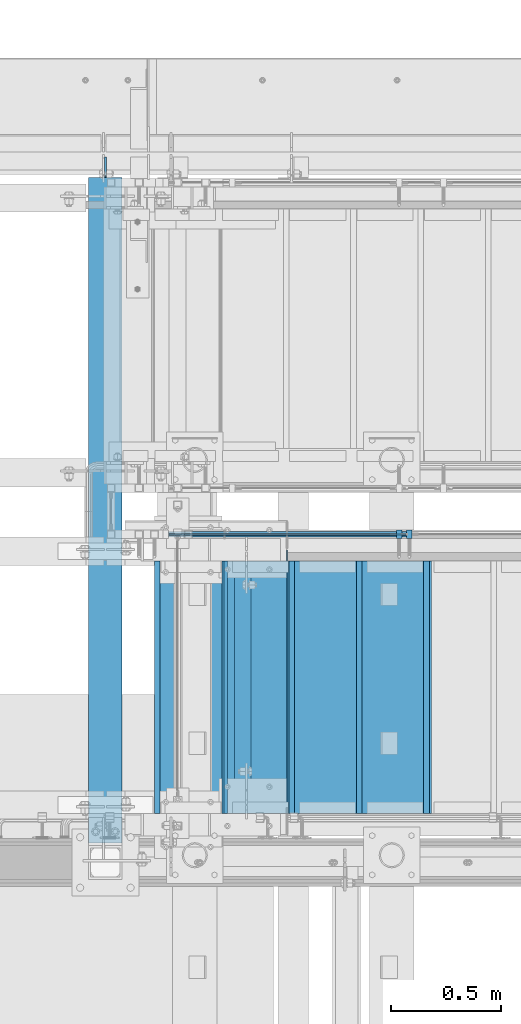
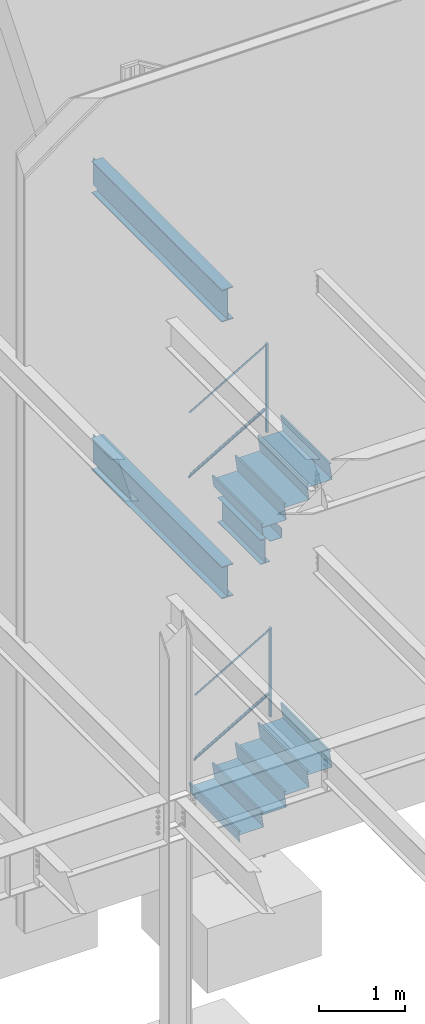
# One storey, part 781 of 1179: 17 beams, 4 members, 7 elements without a shape of their own.
"""IFC2X3 building model written with IfcOpenShell, lengths in millimetres."""

from ifc_helpers import new_model, si_unit, frame, origin_with_axes, place, context, subcontext, project, spatial, faceted_brep, material, type_object, element, aggregate, save


model = new_model("IFC2X3")

# Units and contexts
model_context = context("Model", 3, precision=1e-05, world=origin_with_axes())
body_context = subcontext(model_context, "Body", "Model", "MODEL_VIEW")
ifc_project = project(units=[si_unit("LENGTHUNIT", "METRE", prefix="MILLI"), si_unit("AREAUNIT", "SQUARE_METRE"), si_unit("VOLUMEUNIT", "CUBIC_METRE"), si_unit("MASSUNIT", "GRAM", prefix="KILO"), si_unit("TIMEUNIT", "SECOND"), si_unit("PLANEANGLEUNIT", "RADIAN"), si_unit("SOLIDANGLEUNIT", "STERADIAN"), si_unit("THERMODYNAMICTEMPERATUREUNIT", "DEGREE_CELSIUS"), si_unit("LUMINOUSINTENSITYUNIT", "LUMEN")], contexts=[model_context])

# Site, building, storey
site_placement = place(None, origin_with_axes())
site = spatial("IfcSite", under=ifc_project, at=site_placement, CompositionType="ELEMENT")
building_placement = place(site_placement, origin_with_axes())
building = spatial("IfcBuilding", under=site, at=building_placement, Name="Undefined", CompositionType="ELEMENT")
storey_placement = place(building_placement, origin_with_axes())
storey = spatial("IfcBuildingStorey", under=building, at=storey_placement, Name="Undefined", CompositionType="ELEMENT", Elevation=0.0)

# Assembly, member
assembly_1_placement = place(storey_placement, origin_with_axes())
assembly_1 = element("IfcElementAssembly", 1, at=assembly_1_placement, inside=storey, Name="GUARDRAIL", AssemblyPlace="NOTDEFINED", PredefinedType="RIGID_FRAME")
ifc_material_1 = material(Name="STEEL/A36")
member_type_1 = type_object("IfcMemberType", PredefinedType="NOTDEFINED")
member_1_placement = place(assembly_1_placement, frame((20608.9249611471, 39471.5999992249, 4675.98734774651), z_axis=(0.0, -1.0, 0.0), x_axis=(0.0, 0.0, 1.0)))
member_1 = element("IfcMember", 2, at=member_1_placement, type_object=member_type_1, material=ifc_material_1, Name="POST", context=body_context, shape_type="Brep", body=[
    faceted_brep([(0.0, 12.7000000000007, -19.0500000000029), (0.0, 12.7000000000007, 19.0500000000029), (1243.17712591994, 12.7000000000007, 19.0500000000029), (1243.17712591994, 12.7000000000007, -19.0500000000029), (0.0, -12.7000000000007, 19.0500000000029), (1257.99379259886, -12.7000000000007, 19.0500000000029), (0.0, -12.7000000000007, -19.0500000000029), (1257.99379259886, -12.7000000000007, -19.0500000000029)], [[[0, 1, 2, 3]], [[1, 4, 5, 2]], [[4, 6, 7, 5]], [[6, 0, 3, 7]], [[5, 7, 3, 2]], [[6, 4, 1, 0]]]),
])

assembly_2_placement = place(storey_placement, origin_with_axes())
assembly_2 = element("IfcElementAssembly", 3, at=assembly_2_placement, inside=storey, Name="GUARDRAIL", AssemblyPlace="NOTDEFINED", PredefinedType="RIGID_FRAME")
member_2_placement = place(assembly_2_placement, frame((20655.4916297361, 39471.5999999818, 639.554612166878), z_axis=(0.0, -1.0, 0.0), x_axis=(0.0, 0.0, 1.0)))
member_2 = element("IfcMember", 4, at=member_2_placement, type_object=member_type_1, material=ifc_material_1, Name="POST", context=body_context, shape_type="Brep", body=[
    faceted_brep([(0.0, 12.7000000000007, -19.0500000000029), (0.0, 12.7000000000007, 19.0500000000029), (1242.88603593101, 12.7000000000007, 19.0500000000029), (1242.88603593101, 12.7000000000007, -19.0500000000029), (0.0, -12.7000000000007, 19.0500000000029), (1257.59245954642, -12.7000000000007, 19.0500000000029), (0.0, -12.7000000000007, -19.0500000000029), (1257.59245954642, -12.7000000000007, -19.0500000000029)], [[[0, 1, 2, 3]], [[1, 4, 5, 2]], [[4, 6, 7, 5]], [[6, 0, 3, 7]], [[5, 7, 3, 2]], [[6, 4, 1, 0]]]),
])

# Beam
ifc_material_2 = material(Name="STEEL/BUY-OUT")
beam_type_1 = type_object("IfcBeamType", PredefinedType="NOTDEFINED")
beam_1_placement = place(assembly_1_placement, frame((20092.8747927259, 39468.4251646336, 5594.30006097899), z_axis=(-0.86377890071706, 0.0, -0.503871025835012), x_axis=(-0.503871025835012, 0.0, 0.86377890071706)))
beam_1 = element("IfcBeam", 5, at=beam_1_placement, type_object=beam_type_1, material=ifc_material_2, Name="U-EDGE", context=body_context, shape_type="Brep", body=[
    faceted_brep([(-2.62571120401844e-09, 1.58750000000146, -551.090159790514), (22.2250002407682, 1.58750000000146, -589.784707497234), (22.2250002534201, 4.76249998393178, -589.784707519266), (5.1261577027617e-07, 4.76249998815911, -551.090160687567), (5.1261577027617e-07, 7.93749998815474, -551.090160687567), (25.400000253393, 7.93749998378189, -595.312499999403), (25.4000002406228, -1.58750000000146, -595.312499999232), (-2.62571120401844e-09, -1.58750000000146, -551.090159790514), (25.4000002718667, -1.58750000000146, 595.312499998905), (2.76122591458261e-09, -1.58750000000146, 580.723427522342), (2.76122591458261e-09, 1.58750000000146, 580.723427522342), (22.2250002718201, 1.58750000000146, 593.488867387849), (22.2250002590899, 4.76250001617154, 593.48886738054), (5.1151801017113e-07, 4.76250001247536, 580.723427814559), (5.1151801017113e-07, 7.93750001247827, 580.723427814559), (25.4000002590974, 7.93750001621811, 595.31249999873)], [[[0, 1, 2, 3, 4, 5, 6, 7]], [[7, 6, 8, 9]], [[0, 7, 9, 10]], [[1, 0, 10, 11]], [[2, 1, 11, 12]], [[3, 2, 12, 13]], [[4, 3, 13, 14]], [[5, 4, 14, 15]], [[6, 5, 15, 8]], [[14, 13, 12, 11, 10, 9, 8, 15]]]),
])

beam_2_placement = place(assembly_1_placement, frame((20067.2781716815, 39468.4251646336, 4730.12997777495), z_axis=(-0.86377890071706, 0.0, -0.503871025835012), x_axis=(0.503871110270223, 0.0, -0.863778851463181)))
beam_2 = element("IfcBeam", 6, at=beam_2_placement, type_object=beam_type_1, material=ifc_material_2, Name="U-EDGE", context=body_context, shape_type="Brep", body=[
    faceted_brep([(3.39150574291125e-09, 1.58750000000146, 551.090060740255), (3.39150574291125e-09, -1.58750000000146, 551.090060740255), (22.2249999259266, -1.58750000000146, 589.784086195607), (22.2249999386131, -4.76249998396088, 589.784086217693), (-1.22384335554671e-07, -4.76249998815911, 551.090060521277), (-1.22384335554671e-07, -7.93749998815474, 551.090060521277), (25.3999999386497, -7.93749998381099, 595.312500000691), (25.3999999258431, 1.58750000000146, 595.31250000052), (25.3999999312882, -7.93750001618173, -595.312500000728), (25.3999999440939, 1.58750000000146, -595.312500000899), (-3.57522367266938e-09, 1.58750000000146, -580.72370144297), (-3.57522367266938e-09, -1.58750000000146, -580.72370144297), (22.2249999440628, -1.58750000000146, -593.488900187338), (22.2249999312971, -4.76250001613516, -593.488900180007), (-1.35833943204489e-07, -4.76250001247536, -580.723701367002), (-1.35833943204489e-07, -7.93750001247827, -580.723701367002)], [[[0, 1, 2, 3, 4, 5, 6, 7]], [[7, 6, 8, 9]], [[0, 7, 9, 10]], [[1, 0, 10, 11]], [[2, 1, 11, 12]], [[3, 2, 12, 13]], [[4, 3, 13, 14]], [[5, 4, 14, 15]], [[6, 5, 15, 8]], [[14, 13, 12, 11, 10, 9, 8, 15]]]),
])

beam_3_placement = place(assembly_2_placement, frame((20151.1068581109, 39468.4251653905, 1566.57390567071), z_axis=(-0.86540914081269, 0.0, -0.501065882891503), x_axis=(-0.501065882891504, 0.0, 0.86540914081269)))
beam_3 = element("IfcBeam", 7, at=beam_3_placement, type_object=beam_type_1, material=ifc_material_2, Name="U-EDGE", context=body_context, shape_type="Brep", body=[
    faceted_brep([(5.01850081491284e-07, 7.93750000584987, 565.654393641868), (5.01850081491284e-07, 4.76250000584696, 565.654393641868), (22.2250002528726, 4.76250000758591, 578.467765219681), (22.2250002588062, 1.58750000000146, 578.467765223097), (1.87355908565223e-09, 1.58750000000146, 565.654393353612), (1.87355908565223e-09, -1.58750000000146, 565.654393353612), (25.4000002588291, -1.58750000000146, 580.298246897597), (25.4000002528755, 7.93750000761065, 580.298246894159), (25.4000002430021, -1.58750000000146, -581.025000000453), (25.4000002489647, 7.9374999923748, -581.025000000533), (5.01226168125868e-07, 7.93749999444117, -536.968296245806), (5.01226168125868e-07, 4.76249999444553, -536.968296245806), (22.2250002489855, 4.76249999245192, -575.517911967814), (22.225000243081, 1.58750000000146, -575.51791195757), (-1.78260961547494e-09, 1.58750000000146, -536.968295373328), (-1.78260961547494e-09, -1.58750000000146, -536.968295373328)], [[[0, 1, 2, 3, 4, 5, 6, 7]], [[7, 6, 8, 9]], [[0, 7, 9, 10]], [[1, 0, 10, 11]], [[2, 1, 11, 12]], [[3, 2, 12, 13]], [[4, 3, 13, 14]], [[5, 4, 14, 15]], [[6, 5, 15, 8]], [[14, 13, 12, 11, 10, 9, 8, 15]]]),
])

beam_4_placement = place(assembly_2_placement, frame((20125.6526788242, 39468.4251653905, 701.503466228078), z_axis=(-0.86540914081269, 0.0, -0.501065882891503), x_axis=(0.501065782098943, 0.0, -0.865409199170875)))
beam_4 = element("IfcBeam", 8, at=beam_4_placement, type_object=beam_type_1, material=ifc_material_2, Name="U-EDGE", context=body_context, shape_type="Brep", body=[
    faceted_brep([(-3.45607986673713e-10, 1.58750000000146, 536.241472034682), (-3.45607986673713e-10, -1.58750000000146, 536.241472034682), (22.2250001997436, -1.58750000000146, 574.791082474552), (22.2250002132259, -4.76249998287676, 574.791082497944), (4.30125510320067e-07, -4.76249998738058, 536.241472781338), (4.30125510320067e-07, -7.93749998737621, 536.241472781338), (25.400000213227, -7.93749998271232, 580.298169654056), (25.4000001996137, 1.58750000000146, 580.298169630441), (25.4000002140147, -7.93750001730223, -581.024999999514), (25.4000002276443, 1.58750000000146, -581.0249999997), (3.69254848919809e-10, 1.58750000000146, -566.38114146873), (3.69254848919809e-10, -1.58750000000146, -566.38114146873), (22.2250002275978, -1.58750000000146, -579.194516836025), (22.2250002140099, -4.76250001724839, -579.194516828193), (4.23933670390397e-07, -4.76250001332664, -566.381141712925), (4.23933670390397e-07, -7.93750001332955, -566.381141712925)], [[[0, 1, 2, 3, 4, 5, 6, 7]], [[7, 6, 8, 9]], [[0, 7, 9, 10]], [[1, 0, 10, 11]], [[2, 1, 11, 12]], [[3, 2, 12, 13]], [[4, 3, 13, 14]], [[5, 4, 14, 15]], [[6, 5, 15, 8]], [[14, 13, 12, 11, 10, 9, 8, 15]]]),
])

# Member
member_type_2 = type_object("IfcMemberType", PredefinedType="NOTDEFINED")
member_3_placement = place(assembly_1_placement, frame((19551.6499976883, 39471.5999992249, 4390.05744055561), z_axis=(0.0, -1.0, 0.0), x_axis=(0.863778900717086, 0.0, 0.503871025834967)))
member_3 = element("IfcMember", 9, at=member_3_placement, type_object=member_type_2, material=ifc_material_1, Name="BOTTOM_RAIL", context=body_context, shape_type="Brep", body=[
    faceted_brep([(1213.01228510623, 6.35000000066339, 12.6999999999971), (1205.60395629769, -6.3499999993337, 12.6999999999971), (1205.60395629769, -6.3499999993337, -12.6999999999971), (1213.01228510623, 6.35000000066339, -12.6999999999971), (18.4069803798266, 6.34999999998945, 12.6999999999971), (18.4069803798266, 6.34999999998945, -12.6999999999971), (10.9986698027969, -6.35000000000309, -12.6999999999971), (10.9986698027969, -6.35000000000309, 12.6999999999971)], [[[0, 1, 2, 3]], [[4, 5, 6, 7]], [[5, 4, 0, 3]], [[6, 5, 3, 2]], [[7, 6, 2, 1]], [[4, 7, 1, 0]]]),
])

aggregate(assembly_1, [beam_1, beam_2, member_3, member_1])

member_4_placement = place(assembly_2_placement, frame((19621.5000005731, 39471.5999999818, 371.071282857685), z_axis=(0.0, -1.0, 0.0), x_axis=(0.86540914081267, 0.0, 0.501065882891537)))
member_4 = element("IfcMember", 10, at=member_4_placement, type_object=member_type_2, material=ifc_material_1, Name="BOTTOM_RAIL", context=body_context, shape_type="Brep", body=[
    faceted_brep([(1183.80237647433, 6.34999999946194, 12.6999999999971), (1176.44916466662, -6.35000000052969, 12.6999999999971), (1176.44916466662, -6.35000000052969, -12.6999999999971), (1183.80237647433, 6.34999999946194, -12.6999999999971), (18.3517455546971, 6.34999999998763, 12.6999999999971), (18.3517455546971, 6.34999999998763, -12.6999999999971), (10.9985337469952, -6.35000000000582, -12.6999999999971), (10.9985337469952, -6.35000000000582, 12.6999999999971)], [[[0, 1, 2, 3]], [[4, 5, 6, 7]], [[5, 4, 0, 3]], [[6, 5, 3, 2]], [[7, 6, 2, 1]], [[4, 7, 1, 0]]]),
])

aggregate(assembly_2, [beam_3, member_4, beam_4, member_2])

# Assembly, beams
assembly_3_placement = place(storey_placement, origin_with_axes())
assembly_3 = element("IfcElementAssembly", 11, at=assembly_3_placement, inside=storey, Name="BEAM", AssemblyPlace="NOTDEFINED", PredefinedType="RIGID_FRAME")
ifc_material_3 = material(Name="STEEL/A992")
beam_type_2 = type_object("IfcBeamType", Name="W14X22", PredefinedType="NOTDEFINED")
beam_5_placement = place(assembly_3_placement, frame((19926.3, 38274.6249999907, 3927.475), z_axis=(0.0, 0.0, 1.0), x_axis=(0.0, 1.0, 0.0)))
beam_5 = element("IfcBeam", 12, at=beam_5_placement, type_object=beam_type_2, material=ifc_material_3, Name="BEAM", ObjectType="W14X22", context=body_context, shape_type="Brep", body=[
    faceted_brep([(47.6250000097862, -63.5, -174.625), (47.6250000097862, 63.5, -174.625), (1044.5750000186, 63.5, -174.625), (1044.5750000186, -63.5, -174.625), (47.6250000097862, -63.5, -166.6875), (47.6250000097862, -3.17499999999927, -166.6875), (47.6250000097862, -3.17499999999927, 166.6875), (47.6250000097862, -63.5, 166.6875), (47.6250000097862, -63.5, 174.625), (47.6250000097862, 63.5, 174.625), (47.6250000097862, 63.5, 166.6875), (47.6250000097862, 3.17499999999927, 166.6875), (47.6250000097862, 3.17499999999927, 137.265000000094), (47.6250000097862, 3.17499999999927, -92.8149999999823), (47.6250000097862, 3.17499999999927, -166.6875), (47.6250000097862, 63.5, -166.6875), (1044.5750000186, -63.5, -166.6875), (1044.5750000186, -3.17499999999927, -166.6875), (1044.5750000186, -3.17499999999927, 166.6875), (1044.5750000186, -63.5, 166.6875), (1044.5750000186, -63.5, 174.625), (1044.5750000186, 63.5, 174.625), (1044.5750000186, 63.5, 166.6875), (1044.5750000186, 3.17499999999927, 166.6875), (1044.5750000186, 3.17499999999927, 137.265000000094), (1044.5750000186, 3.17499999999927, -92.8149999999823), (1044.5750000186, 3.17499999999927, -166.6875), (1044.5750000186, 63.5, -166.6875)], [[[0, 1, 2, 3]], [[0, 4, 5, 6, 7, 8, 9, 10, 11, 12, 13, 14, 15, 1]], [[5, 4, 16, 17]], [[6, 5, 17, 18]], [[7, 6, 18, 19]], [[8, 7, 19, 20]], [[9, 8, 20, 21]], [[10, 9, 21, 22]], [[11, 10, 22, 23]], [[14, 13, 12, 11, 23, 24, 25, 26]], [[15, 14, 26, 27]], [[1, 15, 27, 2]], [[26, 25, 24, 23, 22, 21, 20, 19, 18, 17, 16, 3, 2, 27]], [[4, 0, 3, 16]]]),
])
beam_type_3 = type_object("IfcBeamType", PredefinedType="NOTDEFINED")
beam_6_placement = place(assembly_3_placement, frame((19939.0, 38820.7250000005, 4105.275), z_axis=(0.0, -1.0, 0.0), x_axis=(1.0, 0.0, 0.0)))
beam_6 = element("IfcBeam", 13, at=beam_6_placement, type_object=beam_type_3, material=ifc_material_1, Name="BENT_PLATE", context=body_context, shape_type="Brep", body=[
    faceted_brep([(0.0, -3.17500000000018, -581.025000000001), (0.0, -3.17500000000018, 581.025000000001), (0.0, 3.17500000000018, 581.025000000001), (0.0, 3.17500000000018, -581.025000000001), (158.75, 3.17500000000018, 581.025000000001), (158.75, 3.17500000000018, -581.025000000001), (165.099999999999, -3.17500000000018, -581.025000000001), (165.099999999999, -3.17500000000018, 581.025000000001), (158.75, 130.175, 581.025000000001), (158.75, 130.175, -581.025000000001), (165.099999999999, 130.175, 581.025000000001), (165.099999999999, 130.175, -581.025000000001)], [[[0, 1, 2, 3]], [[3, 2, 4, 5]], [[1, 0, 6, 7]], [[5, 4, 8, 9]], [[4, 2, 1, 7, 10, 8]], [[7, 6, 11, 10]], [[6, 0, 3, 5, 9, 11]], [[10, 11, 9, 8]]]),
])
aggregate(assembly_3, [beam_6, beam_5])

assembly_4_placement = place(storey_placement, origin_with_axes())
assembly_4 = element("IfcElementAssembly", 14, at=assembly_4_placement, inside=storey, Name="STAIR", AssemblyPlace="NOTDEFINED", PredefinedType="RIGID_FRAME")
beam_type_4 = type_object("IfcBeamType", PredefinedType="NOTDEFINED")
beam_7_placement = place(assembly_4_placement, frame((20745.4500001582, 38779.4500001282, 4945.36000000019), z_axis=(0.0, -1.0, 0.0), x_axis=(-1.0, 0.0, 0.0)))
beam_7 = element("IfcBeam", 15, at=beam_7_placement, type_object=beam_type_4, material=ifc_material_1, Name="TREAD", context=body_context, shape_type="Brep", body=[
    faceted_brep([(0.0, -1.28999999999996, -571.5), (0.0, -1.28999999999996, 571.5), (0.0, 1.28999999999996, 571.5), (0.0, 1.28999999999996, -571.5), (22.4252350064853, 1.28999999999996, 571.5), (22.4252350064853, 1.28999999999996, -571.5), (25.4000000000015, -1.28999999999996, -571.5), (25.4000000000015, -1.28999999999996, 571.5), (-10.2319078506589, 229.89, 571.5), (-10.2319078506589, 229.89, -571.5), (-7.25714285714275, 227.31, -571.5), (-7.25714285714275, 227.31, 571.5), (319.968697988821, 229.89, 571.5), (319.968697988821, 229.89, -571.5), (317.731075852447, 227.31, -571.5), (317.731075852447, 227.31, 571.5), (325.673299218732, 189.957791390602, 571.5), (325.673299218732, 189.957791390602, -571.5), (323.119229525088, 189.592924291511, 571.5), (323.119229525088, 189.592924291511, -571.5)], [[[0, 1, 2, 3]], [[3, 2, 4, 5]], [[1, 0, 6, 7]], [[5, 4, 8, 9]], [[7, 6, 10, 11]], [[9, 8, 12, 13]], [[11, 10, 14, 15]], [[13, 12, 16, 17]], [[12, 8, 4, 2, 1, 7, 11, 15, 18, 16]], [[15, 14, 19, 18]], [[14, 10, 6, 0, 3, 5, 9, 13, 17, 19]], [[18, 19, 17, 16]]]),
])
beam_8_placement = place(assembly_4_placement, frame((20440.6500001811, 38779.4500001282, 4767.56000000019), z_axis=(0.0, -1.0, 0.0), x_axis=(-1.0, 0.0, 0.0)))
beam_8 = element("IfcBeam", 16, at=beam_8_placement, type_object=beam_type_4, material=ifc_material_1, Name="TREAD", context=body_context, shape_type="Brep", body=[
    faceted_brep([(0.0, -1.28999999999996, -571.5), (0.0, -1.28999999999996, 571.5), (0.0, 1.28999999999996, 571.5), (0.0, 1.28999999999996, -571.5), (22.4252350064853, 1.28999999999996, 571.5), (22.4252350064853, 1.28999999999996, -571.5), (25.4000000000015, -1.28999999999996, -571.5), (25.4000000000015, -1.28999999999996, 571.5), (-10.2319078506589, 229.89, 571.5), (-10.2319078506589, 229.89, -571.5), (-7.25714285714275, 227.31, -571.5), (-7.25714285714275, 227.31, 571.5), (319.968697988821, 229.89, 571.5), (319.968697988821, 229.89, -571.5), (317.731075852447, 227.31, -571.5), (317.731075852447, 227.31, 571.5), (325.673299218732, 189.957791390602, 571.5), (325.673299218732, 189.957791390602, -571.5), (323.119229525088, 189.592924291511, 571.5), (323.119229525088, 189.592924291511, -571.5)], [[[0, 1, 2, 3]], [[3, 2, 4, 5]], [[1, 0, 6, 7]], [[5, 4, 8, 9]], [[7, 6, 10, 11]], [[9, 8, 12, 13]], [[11, 10, 14, 15]], [[13, 12, 16, 17]], [[12, 8, 4, 2, 1, 7, 11, 15, 18, 16]], [[15, 14, 19, 18]], [[14, 10, 6, 0, 3, 5, 9, 13, 17, 19]], [[18, 19, 17, 16]]]),
])
beam_9_placement = place(assembly_4_placement, frame((20135.8500002041, 38779.4500001282, 4589.76000000019), z_axis=(0.0, -1.0, 0.0), x_axis=(-1.0, 0.0, 0.0)))
beam_9 = element("IfcBeam", 17, at=beam_9_placement, type_object=beam_type_4, material=ifc_material_1, Name="TREAD", context=body_context, shape_type="Brep", body=[
    faceted_brep([(0.0, -1.28999999999996, -571.5), (0.0, -1.28999999999996, 571.5), (0.0, 1.28999999999996, 571.5), (0.0, 1.28999999999996, -571.5), (22.4252350064853, 1.28999999999996, 571.5), (22.4252350064853, 1.28999999999996, -571.5), (25.4000000000015, -1.28999999999996, -571.5), (25.4000000000015, -1.28999999999996, 571.5), (-10.2319078506589, 229.89, 571.5), (-10.2319078506589, 229.89, -571.5), (-7.25714285714275, 227.31, -571.5), (-7.25714285714275, 227.31, 571.5), (319.968697988821, 229.89, 571.5), (319.968697988821, 229.89, -571.5), (317.731075852447, 227.31, -571.5), (317.731075852447, 227.31, 571.5), (325.673299218732, 189.957791390602, 571.5), (325.673299218732, 189.957791390602, -571.5), (323.119229525088, 189.592924291511, 571.5), (323.119229525088, 189.592924291511, -571.5)], [[[0, 1, 2, 3]], [[3, 2, 4, 5]], [[1, 0, 6, 7]], [[5, 4, 8, 9]], [[7, 6, 10, 11]], [[9, 8, 12, 13]], [[11, 10, 14, 15]], [[13, 12, 16, 17]], [[12, 8, 4, 2, 1, 7, 11, 15, 18, 16]], [[15, 14, 19, 18]], [[14, 10, 6, 0, 3, 5, 9, 13, 17, 19]], [[18, 19, 17, 16]]]),
])

assembly_5_placement = place(storey_placement, origin_with_axes())
assembly_5 = element("IfcElementAssembly", 18, at=assembly_5_placement, inside=storey, Name="STAIR", AssemblyPlace="NOTDEFINED", PredefinedType="RIGID_FRAME")
beam_10_placement = place(assembly_5_placement, frame((20745.4500002204, 38779.4500000327, 881.095416400779), z_axis=(0.0, -1.0, 0.0), x_axis=(-1.0, 0.0, 0.0)))
beam_10 = element("IfcBeam", 19, at=beam_10_placement, type_object=beam_type_4, material=ifc_material_1, Name="TREAD", context=body_context, shape_type="Brep", body=[
    faceted_brep([(0.0, -1.28999999999996, -571.5), (0.0, -1.28999999999996, 571.5), (0.0, 1.28999999999996, 571.5), (0.0, 1.28999999999996, -571.5), (22.4220799334253, 1.28999999999996, 571.5), (22.4220799334253, 1.28999999999996, -571.5), (25.4000000000015, -1.28999999999996, -571.5), (25.4000000000015, -1.28999999999996, 571.5), (-10.2894642965184, 228.56708328371, 571.5), (-10.2894642965184, 228.56708328371, -571.5), (-7.31154422994223, 225.98708328371, -571.5), (-7.31154422994223, 225.98708328371, 571.5), (319.911141878769, 228.56708328371, 571.5), (319.911141878769, 228.56708328371, -571.5), (317.675890478069, 225.98708328371, -571.5), (317.675890478069, 225.98708328371, 571.5), (325.657303794516, 188.643229151176, 571.5), (325.657303794516, 188.643229151176, -571.5), (323.103618368372, 188.27568222317, 571.5), (323.103618368372, 188.27568222317, -571.5)], [[[0, 1, 2, 3]], [[3, 2, 4, 5]], [[1, 0, 6, 7]], [[5, 4, 8, 9]], [[7, 6, 10, 11]], [[9, 8, 12, 13]], [[11, 10, 14, 15]], [[13, 12, 16, 17]], [[12, 8, 4, 2, 1, 7, 11, 15, 18, 16]], [[15, 14, 19, 18]], [[14, 10, 6, 0, 3, 5, 9, 13, 17, 19]], [[18, 19, 17, 16]]]),
])
beam_11_placement = place(assembly_5_placement, frame((20440.6500001937, 38779.450000034, 704.61833312158), z_axis=(0.0, -1.0, 0.0), x_axis=(-1.0, 0.0, 0.0)))
beam_11 = element("IfcBeam", 20, at=beam_11_placement, type_object=beam_type_4, material=ifc_material_1, Name="TREAD", context=body_context, shape_type="Brep", body=[
    faceted_brep([(0.0, -1.28999999999996, -571.5), (0.0, -1.28999999999996, 571.5), (0.0, 1.28999999999996, 571.5), (0.0, 1.28999999999996, -571.5), (22.4220799334253, 1.28999999999996, 571.5), (22.4220799334253, 1.28999999999996, -571.5), (25.4000000000015, -1.28999999999996, -571.5), (25.4000000000015, -1.28999999999996, 571.5), (-10.2894642965184, 228.56708328371, 571.5), (-10.2894642965184, 228.56708328371, -571.5), (-7.31154422994223, 225.98708328371, -571.5), (-7.31154422994223, 225.98708328371, 571.5), (319.911141878769, 228.56708328371, 571.5), (319.911141878769, 228.56708328371, -571.5), (317.675890478069, 225.98708328371, -571.5), (317.675890478069, 225.98708328371, 571.5), (325.657303794516, 188.643229151176, 571.5), (325.657303794516, 188.643229151176, -571.5), (323.103618368372, 188.27568222317, 571.5), (323.103618368372, 188.27568222317, -571.5)], [[[0, 1, 2, 3]], [[3, 2, 4, 5]], [[1, 0, 6, 7]], [[5, 4, 8, 9]], [[7, 6, 10, 11]], [[9, 8, 12, 13]], [[11, 10, 14, 15]], [[13, 12, 16, 17]], [[12, 8, 4, 2, 1, 7, 11, 15, 18, 16]], [[15, 14, 19, 18]], [[14, 10, 6, 0, 3, 5, 9, 13, 17, 19]], [[18, 19, 17, 16]]]),
])
beam_12_placement = place(assembly_5_placement, frame((20135.8500001669, 38779.4500000353, 528.141249842382), z_axis=(0.0, -1.0, 0.0), x_axis=(-1.0, 0.0, 0.0)))
beam_12 = element("IfcBeam", 21, at=beam_12_placement, type_object=beam_type_4, material=ifc_material_1, Name="TREAD", context=body_context, shape_type="Brep", body=[
    faceted_brep([(0.0, -1.28999999999996, -571.5), (0.0, -1.28999999999996, 571.5), (0.0, 1.28999999999996, 571.5), (0.0, 1.28999999999996, -571.5), (22.4220799334253, 1.28999999999996, 571.5), (22.4220799334253, 1.28999999999996, -571.5), (25.4000000000015, -1.28999999999996, -571.5), (25.4000000000015, -1.28999999999996, 571.5), (-10.2894642965184, 228.56708328371, 571.5), (-10.2894642965184, 228.56708328371, -571.5), (-7.31154422994223, 225.98708328371, -571.5), (-7.31154422994223, 225.98708328371, 571.5), (319.911141878769, 228.56708328371, 571.5), (319.911141878769, 228.56708328371, -571.5), (317.675890478069, 225.98708328371, -571.5), (317.675890478069, 225.98708328371, 571.5), (325.657303794516, 188.643229151176, 571.5), (325.657303794516, 188.643229151176, -571.5), (323.103618368372, 188.27568222317, 571.5), (323.103618368372, 188.27568222317, -571.5)], [[[0, 1, 2, 3]], [[3, 2, 4, 5]], [[1, 0, 6, 7]], [[5, 4, 8, 9]], [[7, 6, 10, 11]], [[9, 8, 12, 13]], [[11, 10, 14, 15]], [[13, 12, 16, 17]], [[12, 8, 4, 2, 1, 7, 11, 15, 18, 16]], [[15, 14, 19, 18]], [[14, 10, 6, 0, 3, 5, 9, 13, 17, 19]], [[18, 19, 17, 16]]]),
])
beam_13_placement = place(assembly_5_placement, frame((19831.0500001401, 38779.4500000366, 351.664166563183), z_axis=(0.0, -1.0, 0.0), x_axis=(-1.0, 0.0, 0.0)))
beam_13 = element("IfcBeam", 22, at=beam_13_placement, type_object=beam_type_4, material=ifc_material_1, Name="TREAD", context=body_context, shape_type="Brep", body=[
    faceted_brep([(0.0, -1.28999999999996, -571.5), (0.0, -1.28999999999996, 571.5), (0.0, 1.28999999999996, 571.5), (0.0, 1.28999999999996, -571.5), (22.4220799334253, 1.28999999999996, 571.5), (22.4220799334253, 1.28999999999996, -571.5), (25.4000000000015, -1.28999999999996, -571.5), (25.4000000000015, -1.28999999999996, 571.5), (-10.2894642965184, 228.56708328371, 571.5), (-10.2894642965184, 228.56708328371, -571.5), (-7.31154422994223, 225.98708328371, -571.5), (-7.31154422994223, 225.98708328371, 571.5), (319.911141878769, 228.56708328371, 571.5), (319.911141878769, 228.56708328371, -571.5), (317.675890478069, 225.98708328371, -571.5), (317.675890478069, 225.98708328371, 571.5), (325.657303794516, 188.643229151176, 571.5), (325.657303794516, 188.643229151176, -571.5), (323.103618368372, 188.27568222317, 571.5), (323.103618368372, 188.27568222317, -571.5)], [[[0, 1, 2, 3]], [[3, 2, 4, 5]], [[1, 0, 6, 7]], [[5, 4, 8, 9]], [[7, 6, 10, 11]], [[9, 8, 12, 13]], [[11, 10, 14, 15]], [[13, 12, 16, 17]], [[12, 8, 4, 2, 1, 7, 11, 15, 18, 16]], [[15, 14, 19, 18]], [[14, 10, 6, 0, 3, 5, 9, 13, 17, 19]], [[18, 19, 17, 16]]]),
])

# Beam
beam_type_5 = type_object("IfcBeamType", PredefinedType="NOTDEFINED")
beam_14_placement = place(assembly_4_placement, frame((19831.050000227, 38779.4500001282, 4411.9600000001), z_axis=(0.0, -1.0, 0.0), x_axis=(-1.0, 0.0, 0.0)))
beam_14 = element("IfcBeam", 23, at=beam_14_placement, type_object=beam_type_5, material=ifc_material_1, Name="TREAD", context=body_context, shape_type="Brep", body=[
    faceted_brep([(0.0, -1.28999999999996, -571.5), (0.0, -1.28999999999996, 571.5), (0.0, 1.28999999999996, 571.5), (0.0, 1.28999999999996, -571.5), (22.4252350064853, 1.28999999999996, 571.5), (22.4252350064853, 1.28999999999996, -571.5), (25.4000000000015, -1.28999999999996, -571.5), (25.4000000000015, -1.28999999999996, 571.5), (-0.73978397951214, 163.445132900907, 571.5), (-0.73978397951214, 163.445132900907, -571.5), (1.81428571413198, 163.810000000002, 571.5), (1.81428571413198, 163.810000000002, -571.5)], [[[0, 1, 2, 3]], [[3, 2, 4, 5]], [[1, 0, 6, 7]], [[5, 4, 8, 9]], [[4, 2, 1, 7, 10, 8]], [[7, 6, 11, 10]], [[6, 0, 3, 5, 9, 11]], [[10, 11, 9, 8]]]),
])

aggregate(assembly_4, [beam_7, beam_8, beam_9, beam_14])

beam_type_6 = type_object("IfcBeamType", PredefinedType="NOTDEFINED")
beam_15_placement = place(assembly_5_placement, frame((19526.2500001134, 38779.4500000379, 175.187083283932), z_axis=(0.0, -1.0, 0.0), x_axis=(-1.0, 0.0, 0.0)))
beam_15 = element("IfcBeam", 24, at=beam_15_placement, type_object=beam_type_6, material=ifc_material_1, Name="TREAD", context=body_context, shape_type="Brep", body=[
    faceted_brep([(0.0, -1.28999999999996, -571.5), (0.0, -1.28999999999996, 571.5), (0.0, 1.28999999999996, 571.5), (0.0, 1.28999999999996, -571.5), (22.4220799334253, 1.28999999999996, 571.5), (22.4220799334253, 1.28999999999996, -571.5), (25.4000000000015, -1.28999999999996, -571.5), (25.4000000000015, -1.28999999999996, 571.5), (-0.716273735204595, 162.053353076738, 571.5), (-0.716273735204595, 162.053353076738, -571.5), (1.83741169093992, 162.420900004753, 571.5), (1.83741169093992, 162.420900004753, -571.5)], [[[0, 1, 2, 3]], [[3, 2, 4, 5]], [[1, 0, 6, 7]], [[5, 4, 8, 9]], [[4, 2, 1, 7, 10, 8]], [[7, 6, 11, 10]], [[6, 0, 3, 5, 9, 11]], [[10, 11, 9, 8]]]),
])

aggregate(assembly_5, [beam_10, beam_11, beam_12, beam_13, beam_15])

# Assembly, beam
assembly_6_placement = place(storey_placement, origin_with_axes())
assembly_6 = element("IfcElementAssembly", 25, at=assembly_6_placement, inside=storey, Name="BEAM", AssemblyPlace="NOTDEFINED", PredefinedType="RIGID_FRAME")
beam_type_7 = type_object("IfcBeamType", Name="W18X40", PredefinedType="NOTDEFINED")
beam_16_placement = place(assembly_6_placement, frame((19278.6, 37985.7, 7786.6875), z_axis=(0.0, 0.0, 1.0), x_axis=(0.0, 1.0, 0.0)))
beam_16 = element("IfcBeam", 26, at=beam_16_placement, type_object=beam_type_7, material=ifc_material_3, Name="BEAM", ObjectType="W18X40", context=body_context, shape_type="Brep", body=[
    faceted_brep([(3102.76875, -3.96875, -214.3125), (3102.76875, -76.2000000000007, -214.3125), (3102.76875, -76.2000000000007, -227.0125), (3102.76875, 76.2000000000007, -227.0125), (3102.76875, 76.2000000000007, -214.3125), (3102.76875, 3.96875, -214.3125), (3102.76875, 3.96875, -201.612499809265), (3102.76875, -3.96875, -201.612499809265), (3103.73547992259, 3.96875, -196.752420291219), (3103.73547992259, -3.96875, -196.752420291219), (3106.48849382307, 3.96875, -192.632243823065), (3106.48849382307, -3.96875, -192.632243823065), (3110.60867029122, 3.96875, -189.879229922587), (3110.60867029122, -3.96875, -189.879229922587), (3115.46874980927, 3.96875, -188.912499999999), (3115.46874980927, -3.96875, -188.912499999999), (3194.84375, -3.96875, -188.912499999999), (3194.84375, 3.96875, -188.912499999999), (88.9000000000015, 3.96875, 214.3125), (88.9000000000015, 76.2000000000007, 214.3125), (3102.76875, 76.2000000000007, 214.3125), (3102.76875, 3.96875, 214.3125), (88.9000000000015, -76.2000000000007, -227.0125), (88.9000000000015, -76.2000000000007, -214.3125), (88.9000000000015, -3.96875, -214.3125), (88.9000000000015, -3.96875, 214.3125), (88.9000000000015, -76.2000000000007, 214.3125), (88.9000000000015, -76.2000000000007, 227.0125), (88.9000000000015, 76.2000000000007, 227.0125), (88.9000000000015, 3.96875, -214.3125), (88.9000000000015, 76.2000000000007, -214.3125), (88.9000000000015, 76.2000000000007, -227.0125), (3102.76875, -3.96875, 214.3125), (3102.76875, -76.2000000000007, 214.3125), (3102.76875, -76.2000000000007, 227.0125), (3102.76875, 76.2000000000007, 227.0125), (3102.76875, -3.96875, 201.612499809266), (3102.76875, 3.96875, 201.612499809266), (3103.73547992259, -3.96875, 196.75242029122), (3103.73547992259, 3.96875, 196.75242029122), (3106.48849382307, -3.96875, 192.632243823066), (3106.48849382307, 3.96875, 192.632243823066), (3110.60867029122, -3.96875, 189.879229922588), (3110.60867029122, 3.96875, 189.879229922588), (3115.46874980927, -3.96875, 188.9125), (3115.46874980927, 3.96875, 188.9125), (3194.84375, -3.96875, 188.9125), (3194.84375, 3.96875, 188.9125)], [[[0, 1, 2, 3, 4, 5, 6, 7]], [[7, 6, 8, 9]], [[9, 8, 10, 11]], [[11, 10, 12, 13]], [[13, 12, 14, 15]], [[16, 15, 14, 17]], [[18, 19, 20, 21]], [[22, 23, 24, 25, 26, 27, 28, 19, 18, 29, 30, 31]], [[26, 25, 32, 33]], [[27, 26, 33, 34]], [[28, 27, 34, 35]], [[19, 28, 35, 20]], [[34, 33, 32, 36, 37, 21, 20, 35]], [[38, 39, 37, 36]], [[40, 41, 39, 38]], [[42, 43, 41, 40]], [[44, 45, 43, 42]], [[46, 47, 45, 44]], [[47, 46, 16, 17]], [[12, 10, 8, 6, 5, 29, 18, 21, 37, 39, 41, 43, 45, 47, 17, 14]], [[30, 29, 5, 4]], [[31, 30, 4, 3]], [[22, 31, 3, 2]], [[23, 22, 2, 1]], [[24, 23, 1, 0]], [[46, 44, 42, 40, 38, 36, 32, 25, 24, 0, 7, 9, 11, 13, 15, 16]]]),
])
aggregate(assembly_6, [beam_16])

assembly_7_placement = place(storey_placement, origin_with_axes())
assembly_7 = element("IfcElementAssembly", 27, at=assembly_7_placement, inside=storey, Name="BEAM", AssemblyPlace="NOTDEFINED", PredefinedType="RIGID_FRAME")
beam_17_placement = place(assembly_7_placement, frame((19278.6, 37985.7, 3875.0875), z_axis=(0.0, 0.0, 1.0), x_axis=(0.0, 1.0, 0.0)))
beam_17 = element("IfcBeam", 28, at=beam_17_placement, type_object=beam_type_7, material=ifc_material_3, Name="BEAM", ObjectType="W18X40", context=body_context, shape_type="Brep", body=[
    faceted_brep([(3102.76875, -3.96875, -214.3125), (3102.76875, -76.2000000000007, -214.3125), (3102.76875, -76.2000000000007, -227.0125), (3102.76875, 76.2000000000007, -227.0125), (3102.76875, 76.2000000000007, -214.3125), (3102.76875, 3.96875, -214.3125), (3102.76875, 3.96875, -207.962499809265), (3102.76875, -3.96875, -207.962499809265), (3103.73547992259, 3.96875, -203.102420291219), (3103.73547992259, -3.96875, -203.102420291219), (3106.48849382307, 3.96875, -198.982243823066), (3106.48849382307, -3.96875, -198.982243823066), (3110.60867029122, 3.96875, -196.229229922588), (3110.60867029122, -3.96875, -196.229229922588), (3115.46874980927, 3.96875, -195.2625), (3115.46874980927, -3.96875, -195.2625), (3194.84375, -3.96875, -195.2625), (3194.84375, 3.96875, -195.2625), (88.9000000000015, 3.96875, 214.3125), (88.9000000000015, 76.2000000000007, 214.3125), (3102.76875, 76.2000000000007, 214.3125), (3102.76875, 3.96875, 214.3125), (88.9000000000015, -76.2000000000007, -227.0125), (88.9000000000015, -76.2000000000007, -214.3125), (88.9000000000015, -3.96875, -214.3125), (88.9000000000015, -3.96875, 214.3125), (88.9000000000015, -76.2000000000007, 214.3125), (88.9000000000015, -76.2000000000007, 227.0125), (88.9000000000015, 76.2000000000007, 227.0125), (88.9000000000015, 3.96875, -214.3125), (88.9000000000015, 76.2000000000007, -214.3125), (88.9000000000015, 76.2000000000007, -227.0125), (3102.76875, -3.96875, 214.3125), (3102.76875, -76.2000000000007, 214.3125), (3102.76875, -76.2000000000007, 227.0125), (3102.76875, 76.2000000000007, 227.0125), (3102.76875, -3.96875, 207.962499809265), (3102.76875, 3.96875, 207.962499809265), (3103.73547992259, -3.96875, 203.10242029122), (3103.73547992259, 3.96875, 203.10242029122), (3106.48849382307, -3.96875, 198.982243823066), (3106.48849382307, 3.96875, 198.982243823066), (3110.60867029122, -3.96875, 196.229229922588), (3110.60867029122, 3.96875, 196.229229922588), (3115.46874980927, -3.96875, 195.2625), (3115.46874980927, 3.96875, 195.2625), (3194.84375, -3.96875, 195.2625), (3194.84375, 3.96875, 195.2625)], [[[0, 1, 2, 3, 4, 5, 6, 7]], [[7, 6, 8, 9]], [[9, 8, 10, 11]], [[11, 10, 12, 13]], [[13, 12, 14, 15]], [[16, 15, 14, 17]], [[18, 19, 20, 21]], [[22, 23, 24, 25, 26, 27, 28, 19, 18, 29, 30, 31]], [[26, 25, 32, 33]], [[27, 26, 33, 34]], [[28, 27, 34, 35]], [[19, 28, 35, 20]], [[34, 33, 32, 36, 37, 21, 20, 35]], [[38, 39, 37, 36]], [[40, 41, 39, 38]], [[42, 43, 41, 40]], [[44, 45, 43, 42]], [[46, 47, 45, 44]], [[47, 46, 16, 17]], [[12, 10, 8, 6, 5, 29, 18, 21, 37, 39, 41, 43, 45, 47, 17, 14]], [[30, 29, 5, 4]], [[31, 30, 4, 3]], [[22, 31, 3, 2]], [[23, 22, 2, 1]], [[24, 23, 1, 0]], [[46, 44, 42, 40, 38, 36, 32, 25, 24, 0, 7, 9, 11, 13, 15, 16]]]),
])
aggregate(assembly_7, [beam_17])

save(model, "model.ifc")
